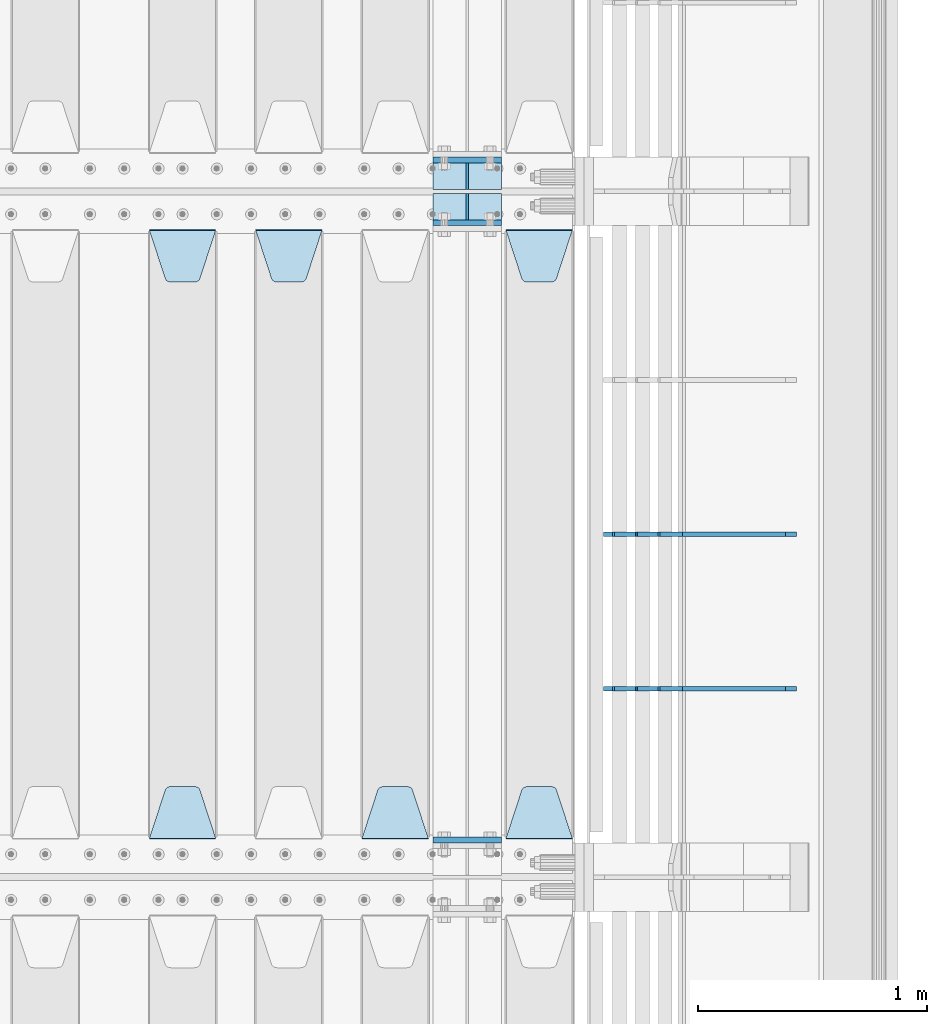
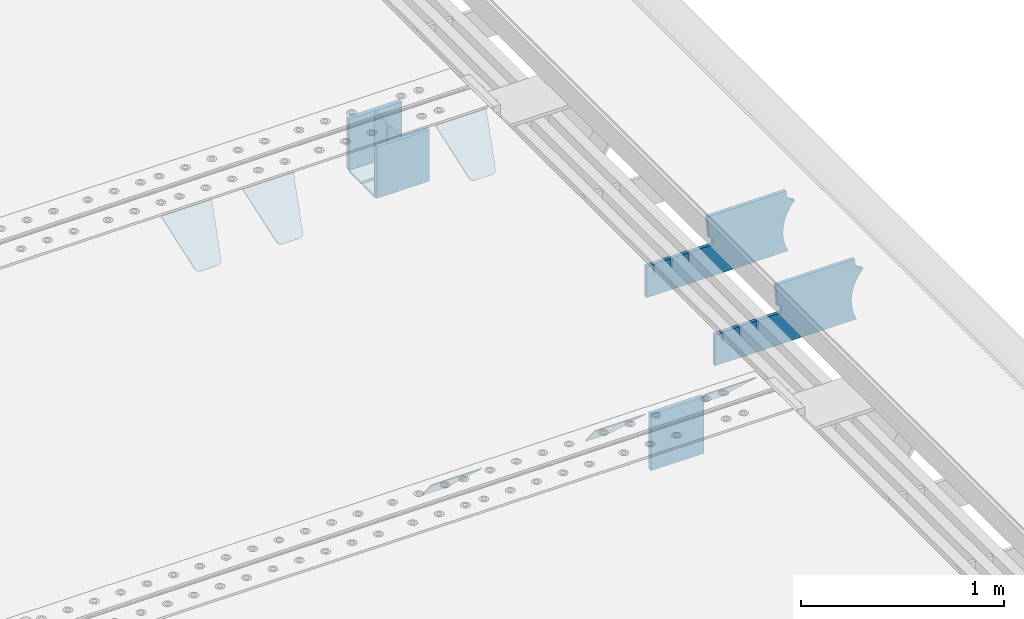
# One storey, part 237 of 257: 15 plates.
"""IFC2X3 building model written with IfcOpenShell, lengths in millimetres."""

from ifc_helpers import new_model, si_unit, frame, origin_with_axes, place, context, subcontext, project, spatial, faceted_brep, material, type_object, element, save


model = new_model("IFC2X3")

# Units and contexts
model_context = context("Model", 3, precision=1e-05, world=origin_with_axes())
body_context = subcontext(model_context, "Body", "Model", "MODEL_VIEW")
ifc_project = project(units=[si_unit("LENGTHUNIT", "METRE", prefix="MILLI"), si_unit("AREAUNIT", "SQUARE_METRE"), si_unit("VOLUMEUNIT", "CUBIC_METRE"), si_unit("MASSUNIT", "GRAM", prefix="KILO"), si_unit("TIMEUNIT", "SECOND"), si_unit("PLANEANGLEUNIT", "RADIAN"), si_unit("SOLIDANGLEUNIT", "STERADIAN"), si_unit("THERMODYNAMICTEMPERATUREUNIT", "DEGREE_CELSIUS"), si_unit("LUMINOUSINTENSITYUNIT", "LUMEN")], contexts=[model_context])

# Site, building, storey
site_placement = place(None, origin_with_axes())
site = spatial("IfcSite", under=ifc_project, at=site_placement, CompositionType="ELEMENT")
building_placement = place(site_placement, origin_with_axes())
building = spatial("IfcBuilding", under=site, at=building_placement, Name="Standard", CompositionType="ELEMENT")
storey_placement = place(building_placement, origin_with_axes())
storey = spatial("IfcBuildingStorey", under=building, at=storey_placement, Name="Undefined", CompositionType="ELEMENT", Elevation=0.0)

# Plates
ifc_material = material(Name="STEEL/S355N")
plate_type_1 = type_object("IfcPlateType", PredefinedType="NOTDEFINED")
for number, where, z_axis, x_axis in (
    (1, (58645.0, 6137.49999999999, -339.999999999993), (0.0, 0.0, 1.0), (1.0, 0.0, 0.0)),
    (2, (58645.0, 5862.49999999999, -339.999999999993), (0.0, 0.0, 1.0), (1.0, 0.0, 0.0)),
):
    element("IfcPlate", number, at=place(storey_placement, frame(where, z_axis=z_axis, x_axis=x_axis)), inside=storey, type_object=plate_type_1, material=ifc_material, context=body_context, shape_type="Brep", body=[
        faceted_brep([(0.0, -12.5, 0.0), (0.0, -12.5, 310.0), (0.0, 12.5, 310.0), (0.0, 12.5, 0.0), (300.0, -12.5, 310.0), (300.0, 12.5, 310.0), (300.0, -12.5, 0.0), (300.0, 12.5, 0.0)], [[[0, 1, 2, 3]], [[1, 4, 5, 2]], [[4, 6, 7, 5]], [[6, 0, 3, 7]], [[5, 7, 3, 2]], [[6, 4, 1, 0]]]),
    ])
plate_1_placement = place(storey_placement, frame((58645.0, 3162.5, -340.000000000044), z_axis=(0.0, 0.0, 1.0), x_axis=(1.0, 0.0, 0.0)))
element("IfcPlate", 3, at=plate_1_placement, inside=storey, type_object=plate_type_1, material=ifc_material, context=body_context, shape_type="Brep", body=[
    faceted_brep([(0.0, -12.5, 0.0), (0.0, -12.5, 340.0), (0.0, 12.5, 340.0), (0.0, 12.5, 0.0), (300.0, -12.5, 340.0), (300.0, 12.5, 340.0), (300.0, -12.5, 0.0), (300.0, 12.5, 0.0)], [[[0, 1, 2, 3]], [[1, 4, 5, 2]], [[4, 6, 7, 5]], [[6, 0, 3, 7]], [[5, 7, 3, 2]], [[6, 4, 1, 0]]]),
])
plate_type_2 = type_object("IfcPlateType", PredefinedType="NOTDEFINED")
for number, where, z_axis, x_axis in (
    (4, (58645.0, 5991.99999999999, -342.999999999993), (0.0, -1.0, 0.0), (1.0, 0.0, 0.0)),
    (5, (58645.0, 6007.99999999999, -342.999999999993), (0.0, 1.0, 0.0), (1.0, 0.0, 0.0)),
):
    element("IfcPlate", number, at=place(storey_placement, frame(where, z_axis=z_axis, x_axis=x_axis)), inside=storey, type_object=plate_type_2, material=ifc_material, context=body_context, shape_type="Brep", body=[
        faceted_brep([(0.0, -7.0, 0.0), (0.0, -7.0, 117.0), (0.0, 7.0, 117.0), (0.0, 7.0, 0.0), (300.0, -7.0, 117.0), (300.0, 7.0, 117.0), (300.0, -7.0, 0.0), (300.0, 7.0, 0.0)], [[[0, 1, 2, 3]], [[1, 4, 5, 2]], [[4, 6, 7, 5]], [[6, 0, 3, 7]], [[5, 7, 3, 2]], [[6, 4, 1, 0]]]),
    ])
plate_type_3 = type_object("IfcPlateType", PredefinedType="NOTDEFINED")
for number, where, z_axis, x_axis in (
    (6, (58795.0, 6007.99999999999, -29.999999999993), (0.0, 0.0, -1.0), (0.0, 1.0, 0.0)),
    (7, (58795.0, 5991.99999999999, -29.999999999993), (0.0, 0.0, -1.0), (0.0, -1.0, 0.0)),
):
    element("IfcPlate", number, at=place(storey_placement, frame(where, z_axis=z_axis, x_axis=x_axis)), inside=storey, type_object=plate_type_3, material=ifc_material, context=body_context, shape_type="Brep", body=[
        faceted_brep([(0.0, -5.0, 30.0), (0.0, -5.0, 306.0), (0.0, 5.0, 306.0), (0.0, 5.0, 30.0), (117.0, -5.0, 306.0), (117.0, 5.0, 306.0), (117.0, -5.0, 0.0), (117.0, 5.0, 0.0), (30.0, -5.0, 0.0), (30.0, 5.0, 0.0), (24.7905546699922, -5.0, 0.455767409633758), (24.7905546699922, 5.0, 0.455767409633758), (19.7393957002296, -5.0, 1.80922137642275), (19.7393957002296, 5.0, 1.80922137642275), (15.0, -5.0, 4.01923788646684), (15.0, 5.0, 4.01923788646684), (10.7163717094036, -5.0, 7.01866670643066), (10.7163717094036, 5.0, 7.01866670643066), (7.01866670643085, -5.0, 10.7163717094038), (7.01866670643085, 5.0, 10.7163717094038), (4.01923788646673, -5.0, 15.0), (4.01923788646673, 5.0, 15.0), (1.80922137642301, -5.0, 19.7393957002299), (1.80922137642301, 5.0, 19.7393957002299), (0.455767409634063, -5.0, 24.7905546699921), (0.455767409634063, 5.0, 24.7905546699921)], [[[0, 1, 2, 3]], [[1, 4, 5, 2]], [[4, 6, 7, 5]], [[6, 8, 9, 7]], [[8, 10, 11, 9]], [[10, 12, 13, 11]], [[12, 14, 15, 13]], [[14, 16, 17, 15]], [[16, 18, 19, 17]], [[18, 20, 21, 19]], [[20, 22, 23, 21]], [[22, 24, 25, 23]], [[24, 0, 3, 25]], [[5, 7, 9, 11, 13, 15, 17, 19, 21, 23, 25, 3, 2]], [[24, 22, 20, 18, 16, 14, 12, 10, 8, 6, 4, 1, 0]]]),
    ])
plate_type_4 = type_object("IfcPlateType", PredefinedType="NOTDEFINED")
plate_2_placement = place(storey_placement, frame((58965.0, 5831.76776695594, -1.767766952965), z_axis=(0.0, -0.707106781186548, -0.707106781186547), x_axis=(1.0, 0.0, 0.0)))
element("IfcPlate", 8, at=plate_2_placement, inside=storey, type_object=plate_type_4, material=ifc_material, context=body_context, shape_type="Brep", body=[
    faceted_brep([(0.0, -2.5, 0.0), (69.345504679477, -2.50000000000091, 300.17173142483), (69.345504679477, 2.5, 300.171731424831), (0.0, 2.5, 0.0), (70.927406119954, -2.50000000000091, 304.8974424154), (70.927406119954, 2.5, 304.8974424154), (73.3818627772271, -2.50000000000091, 309.234538108527), (73.3818627772271, 2.49999999999909, 309.234538108527), (76.6187032999587, -2.5, 313.023683126103), (76.6187032999587, 2.5, 313.023683126103), (80.5190132705029, -2.5, 316.125672595372), (80.5190132705029, 2.5, 316.125672595371), (84.9395038596849, -2.5, 318.426546230476), (84.9395038596849, 2.5, 318.426546230477), (89.7177759439219, -2.5, 319.841774983275), (89.7177759439219, 2.5, 319.841774983275), (94.6782862926484, -2.5, 320.319366455079), (94.6782862926484, 2.5, 320.319366455079), (195.321713707352, -2.5, 320.319366455079), (195.321713707352, 2.5, 320.319366455079), (200.282224056078, -2.5, 319.841774983275), (200.282224056078, 2.49999999999909, 319.841774983275), (205.060496140315, -2.5, 318.426546230476), (205.060496140315, 2.49999999999909, 318.426546230475), (209.480986729497, -2.5, 316.125672595371), (209.480986729497, 2.5, 316.125672595371), (213.381296700041, -2.50000000000091, 313.023683126102), (213.381296700041, 2.5, 313.023683126103), (216.618137222766, -2.50000000000091, 309.234538108527), (216.618137222766, 2.5, 309.234538108527), (219.072593880039, -2.5, 304.897442415399), (219.072593880039, 2.5, 304.897442415399), (220.654495320523, -2.50000000000091, 300.17173142483), (220.654495320523, 2.5, 300.171731424831), (290.0, -2.50000000000091, 0.0), (290.0, 2.5, 9.09494701772928e-13)], [[[0, 1, 2, 3]], [[1, 4, 5, 2]], [[4, 6, 7, 5]], [[6, 8, 9, 7]], [[8, 10, 11, 9]], [[10, 12, 13, 11]], [[12, 14, 15, 13]], [[14, 16, 17, 15]], [[16, 18, 19, 17]], [[18, 20, 21, 19]], [[20, 22, 23, 21]], [[22, 24, 25, 23]], [[24, 26, 27, 25]], [[26, 28, 29, 27]], [[28, 30, 31, 29]], [[30, 32, 33, 31]], [[32, 34, 35, 33]], [[34, 0, 3, 35]], [[5, 7, 9, 11, 13, 15, 17, 19, 21, 23, 25, 27, 29, 31, 33, 35, 3, 2]], [[34, 32, 30, 28, 26, 24, 22, 20, 18, 16, 14, 12, 10, 8, 6, 4, 1, 0]]]),
])
plate_3_placement = place(storey_placement, frame((59255.0, 3168.23223304703, -1.76776695296758), z_axis=(0.0, 0.707106781186547, -0.707106781186548), x_axis=(-1.0, 0.0, 0.0)))
element("IfcPlate", 9, at=plate_3_placement, inside=storey, type_object=plate_type_4, material=ifc_material, context=body_context, shape_type="Brep", body=[
    faceted_brep([(0.0, -2.5, 0.0), (69.345504679477, -2.50000000000091, 300.17173142483), (69.345504679477, 2.5, 300.171731424831), (0.0, 2.5, 0.0), (70.927406119954, -2.50000000000091, 304.8974424154), (70.927406119954, 2.5, 304.8974424154), (73.3818627772271, -2.50000000000091, 309.234538108527), (73.3818627772271, 2.49999999999909, 309.234538108527), (76.6187032999587, -2.5, 313.023683126103), (76.6187032999587, 2.5, 313.023683126103), (80.5190132705029, -2.5, 316.125672595372), (80.5190132705029, 2.5, 316.125672595371), (84.9395038596849, -2.5, 318.426546230476), (84.9395038596849, 2.5, 318.426546230477), (89.7177759439219, -2.5, 319.841774983275), (89.7177759439219, 2.5, 319.841774983275), (94.6782862926484, -2.5, 320.319366455079), (94.6782862926484, 2.5, 320.319366455079), (195.321713707352, -2.5, 320.319366455079), (195.321713707352, 2.5, 320.319366455079), (200.282224056078, -2.5, 319.841774983275), (200.282224056078, 2.49999999999909, 319.841774983275), (205.060496140315, -2.5, 318.426546230476), (205.060496140315, 2.49999999999909, 318.426546230475), (209.480986729497, -2.5, 316.125672595371), (209.480986729497, 2.5, 316.125672595371), (213.381296700041, -2.50000000000091, 313.023683126102), (213.381296700041, 2.5, 313.023683126103), (216.618137222766, -2.50000000000091, 309.234538108527), (216.618137222766, 2.5, 309.234538108527), (219.072593880039, -2.5, 304.897442415399), (219.072593880039, 2.5, 304.897442415399), (220.654495320523, -2.50000000000091, 300.17173142483), (220.654495320523, 2.5, 300.171731424831), (290.0, -2.50000000000091, 0.0), (290.0, 2.5, 9.09494701772928e-13)], [[[0, 1, 2, 3]], [[1, 4, 5, 2]], [[4, 6, 7, 5]], [[6, 8, 9, 7]], [[8, 10, 11, 9]], [[10, 12, 13, 11]], [[12, 14, 15, 13]], [[14, 16, 17, 15]], [[16, 18, 19, 17]], [[18, 20, 21, 19]], [[20, 22, 23, 21]], [[22, 24, 25, 23]], [[24, 26, 27, 25]], [[26, 28, 29, 27]], [[28, 30, 31, 29]], [[30, 32, 33, 31]], [[32, 34, 35, 33]], [[34, 0, 3, 35]], [[5, 7, 9, 11, 13, 15, 17, 19, 21, 23, 25, 27, 29, 31, 33, 35, 3, 2]], [[34, 32, 30, 28, 26, 24, 22, 20, 18, 16, 14, 12, 10, 8, 6, 4, 1, 0]]]),
])
plate_4_placement = place(storey_placement, frame((58625.0, 3168.23223304703, -1.76776695296758), z_axis=(0.0, 0.707106781186547, -0.707106781186548), x_axis=(-1.0, 0.0, 0.0)))
element("IfcPlate", 10, at=plate_4_placement, inside=storey, type_object=plate_type_4, material=ifc_material, context=body_context, shape_type="Brep", body=[
    faceted_brep([(0.0, -2.5, 0.0), (69.345504679477, -2.50000000000091, 300.17173142483), (69.345504679477, 2.5, 300.171731424831), (0.0, 2.5, 0.0), (70.927406119954, -2.50000000000091, 304.8974424154), (70.927406119954, 2.5, 304.8974424154), (73.3818627772271, -2.50000000000091, 309.234538108527), (73.3818627772271, 2.49999999999909, 309.234538108527), (76.6187032999587, -2.5, 313.023683126103), (76.6187032999587, 2.5, 313.023683126103), (80.5190132705029, -2.5, 316.125672595372), (80.5190132705029, 2.5, 316.125672595371), (84.9395038596849, -2.5, 318.426546230476), (84.9395038596849, 2.5, 318.426546230477), (89.7177759439219, -2.5, 319.841774983275), (89.7177759439219, 2.5, 319.841774983275), (94.6782862926484, -2.5, 320.319366455079), (94.6782862926484, 2.5, 320.319366455079), (195.321713707352, -2.5, 320.319366455079), (195.321713707352, 2.5, 320.319366455079), (200.282224056078, -2.5, 319.841774983275), (200.282224056078, 2.49999999999909, 319.841774983275), (205.060496140315, -2.5, 318.426546230476), (205.060496140315, 2.49999999999909, 318.426546230475), (209.480986729497, -2.5, 316.125672595371), (209.480986729497, 2.5, 316.125672595371), (213.381296700041, -2.50000000000091, 313.023683126102), (213.381296700041, 2.5, 313.023683126103), (216.618137222766, -2.50000000000091, 309.234538108527), (216.618137222766, 2.5, 309.234538108527), (219.072593880039, -2.5, 304.897442415399), (219.072593880039, 2.5, 304.897442415399), (220.654495320523, -2.50000000000091, 300.17173142483), (220.654495320523, 2.5, 300.171731424831), (290.0, -2.50000000000091, 0.0), (290.0, 2.5, 9.09494701772928e-13)], [[[0, 1, 2, 3]], [[1, 4, 5, 2]], [[4, 6, 7, 5]], [[6, 8, 9, 7]], [[8, 10, 11, 9]], [[10, 12, 13, 11]], [[12, 14, 15, 13]], [[14, 16, 17, 15]], [[16, 18, 19, 17]], [[18, 20, 21, 19]], [[20, 22, 23, 21]], [[22, 24, 25, 23]], [[24, 26, 27, 25]], [[26, 28, 29, 27]], [[28, 30, 31, 29]], [[30, 32, 33, 31]], [[32, 34, 35, 33]], [[34, 0, 3, 35]], [[5, 7, 9, 11, 13, 15, 17, 19, 21, 23, 25, 27, 29, 31, 33, 35, 3, 2]], [[34, 32, 30, 28, 26, 24, 22, 20, 18, 16, 14, 12, 10, 8, 6, 4, 1, 0]]]),
])
plate_5_placement = place(storey_placement, frame((57870.0, 5831.76776695594, -1.767766952965), z_axis=(0.0, -0.707106781186548, -0.707106781186547), x_axis=(1.0, 0.0, 0.0)))
element("IfcPlate", 11, at=plate_5_placement, inside=storey, type_object=plate_type_4, material=ifc_material, context=body_context, shape_type="Brep", body=[
    faceted_brep([(0.0, -2.5, 0.0), (69.345504679477, -2.50000000000091, 300.17173142483), (69.345504679477, 2.5, 300.171731424831), (0.0, 2.5, 0.0), (70.927406119954, -2.50000000000091, 304.8974424154), (70.927406119954, 2.5, 304.8974424154), (73.3818627772271, -2.50000000000091, 309.234538108527), (73.3818627772271, 2.49999999999909, 309.234538108527), (76.6187032999587, -2.5, 313.023683126103), (76.6187032999587, 2.5, 313.023683126103), (80.5190132705029, -2.5, 316.125672595372), (80.5190132705029, 2.5, 316.125672595371), (84.9395038596849, -2.5, 318.426546230476), (84.9395038596849, 2.5, 318.426546230477), (89.7177759439219, -2.5, 319.841774983275), (89.7177759439219, 2.5, 319.841774983275), (94.6782862926484, -2.5, 320.319366455079), (94.6782862926484, 2.5, 320.319366455079), (195.321713707352, -2.5, 320.319366455079), (195.321713707352, 2.5, 320.319366455079), (200.282224056078, -2.5, 319.841774983275), (200.282224056078, 2.49999999999909, 319.841774983275), (205.060496140315, -2.5, 318.426546230476), (205.060496140315, 2.49999999999909, 318.426546230475), (209.480986729497, -2.5, 316.125672595371), (209.480986729497, 2.5, 316.125672595371), (213.381296700041, -2.50000000000091, 313.023683126102), (213.381296700041, 2.5, 313.023683126103), (216.618137222766, -2.50000000000091, 309.234538108527), (216.618137222766, 2.5, 309.234538108527), (219.072593880039, -2.5, 304.897442415399), (219.072593880039, 2.5, 304.897442415399), (220.654495320523, -2.50000000000091, 300.17173142483), (220.654495320523, 2.5, 300.171731424831), (290.0, -2.50000000000091, 0.0), (290.0, 2.5, 9.09494701772928e-13)], [[[0, 1, 2, 3]], [[1, 4, 5, 2]], [[4, 6, 7, 5]], [[6, 8, 9, 7]], [[8, 10, 11, 9]], [[10, 12, 13, 11]], [[12, 14, 15, 13]], [[14, 16, 17, 15]], [[16, 18, 19, 17]], [[18, 20, 21, 19]], [[20, 22, 23, 21]], [[22, 24, 25, 23]], [[24, 26, 27, 25]], [[26, 28, 29, 27]], [[28, 30, 31, 29]], [[30, 32, 33, 31]], [[32, 34, 35, 33]], [[34, 0, 3, 35]], [[5, 7, 9, 11, 13, 15, 17, 19, 21, 23, 25, 27, 29, 31, 33, 35, 3, 2]], [[34, 32, 30, 28, 26, 24, 22, 20, 18, 16, 14, 12, 10, 8, 6, 4, 1, 0]]]),
])
plate_6_placement = place(storey_placement, frame((57405.0, 5831.76776695594, -1.767766952965), z_axis=(0.0, -0.707106781186548, -0.707106781186547), x_axis=(1.0, 0.0, 0.0)))
element("IfcPlate", 12, at=plate_6_placement, inside=storey, type_object=plate_type_4, material=ifc_material, context=body_context, shape_type="Brep", body=[
    faceted_brep([(0.0, -2.5, 0.0), (69.345504679477, -2.50000000000091, 300.17173142483), (69.345504679477, 2.5, 300.171731424831), (0.0, 2.5, 0.0), (70.927406119954, -2.50000000000091, 304.8974424154), (70.927406119954, 2.5, 304.8974424154), (73.3818627772271, -2.50000000000091, 309.234538108527), (73.3818627772271, 2.49999999999909, 309.234538108527), (76.6187032999587, -2.5, 313.023683126103), (76.6187032999587, 2.5, 313.023683126103), (80.5190132705029, -2.5, 316.125672595372), (80.5190132705029, 2.5, 316.125672595371), (84.9395038596849, -2.5, 318.426546230476), (84.9395038596849, 2.5, 318.426546230477), (89.7177759439219, -2.5, 319.841774983275), (89.7177759439219, 2.5, 319.841774983275), (94.6782862926484, -2.5, 320.319366455079), (94.6782862926484, 2.5, 320.319366455079), (195.321713707352, -2.5, 320.319366455079), (195.321713707352, 2.5, 320.319366455079), (200.282224056078, -2.5, 319.841774983275), (200.282224056078, 2.49999999999909, 319.841774983275), (205.060496140315, -2.5, 318.426546230476), (205.060496140315, 2.49999999999909, 318.426546230475), (209.480986729497, -2.5, 316.125672595371), (209.480986729497, 2.5, 316.125672595371), (213.381296700041, -2.50000000000091, 313.023683126102), (213.381296700041, 2.5, 313.023683126103), (216.618137222766, -2.50000000000091, 309.234538108527), (216.618137222766, 2.5, 309.234538108527), (219.072593880039, -2.5, 304.897442415399), (219.072593880039, 2.5, 304.897442415399), (220.654495320523, -2.50000000000091, 300.17173142483), (220.654495320523, 2.5, 300.171731424831), (290.0, -2.50000000000091, 0.0), (290.0, 2.5, 9.09494701772928e-13)], [[[0, 1, 2, 3]], [[1, 4, 5, 2]], [[4, 6, 7, 5]], [[6, 8, 9, 7]], [[8, 10, 11, 9]], [[10, 12, 13, 11]], [[12, 14, 15, 13]], [[14, 16, 17, 15]], [[16, 18, 19, 17]], [[18, 20, 21, 19]], [[20, 22, 23, 21]], [[22, 24, 25, 23]], [[24, 26, 27, 25]], [[26, 28, 29, 27]], [[28, 30, 31, 29]], [[30, 32, 33, 31]], [[32, 34, 35, 33]], [[34, 0, 3, 35]], [[5, 7, 9, 11, 13, 15, 17, 19, 21, 23, 25, 27, 29, 31, 33, 35, 3, 2]], [[34, 32, 30, 28, 26, 24, 22, 20, 18, 16, 14, 12, 10, 8, 6, 4, 1, 0]]]),
])
plate_7_placement = place(storey_placement, frame((57695.0, 3168.23223304703, -1.76776695296758), z_axis=(0.0, 0.707106781186547, -0.707106781186548), x_axis=(-1.0, 0.0, 0.0)))
element("IfcPlate", 13, at=plate_7_placement, inside=storey, type_object=plate_type_4, material=ifc_material, context=body_context, shape_type="Brep", body=[
    faceted_brep([(0.0, -2.5, 0.0), (69.345504679477, -2.50000000000091, 300.17173142483), (69.345504679477, 2.5, 300.171731424831), (0.0, 2.5, 0.0), (70.927406119954, -2.50000000000091, 304.8974424154), (70.927406119954, 2.5, 304.8974424154), (73.3818627772271, -2.50000000000091, 309.234538108527), (73.3818627772271, 2.49999999999909, 309.234538108527), (76.6187032999587, -2.5, 313.023683126103), (76.6187032999587, 2.5, 313.023683126103), (80.5190132705029, -2.5, 316.125672595372), (80.5190132705029, 2.5, 316.125672595371), (84.9395038596849, -2.5, 318.426546230476), (84.9395038596849, 2.5, 318.426546230477), (89.7177759439219, -2.5, 319.841774983275), (89.7177759439219, 2.5, 319.841774983275), (94.6782862926484, -2.5, 320.319366455079), (94.6782862926484, 2.5, 320.319366455079), (195.321713707352, -2.5, 320.319366455079), (195.321713707352, 2.5, 320.319366455079), (200.282224056078, -2.5, 319.841774983275), (200.282224056078, 2.49999999999909, 319.841774983275), (205.060496140315, -2.5, 318.426546230476), (205.060496140315, 2.49999999999909, 318.426546230475), (209.480986729497, -2.5, 316.125672595371), (209.480986729497, 2.5, 316.125672595371), (213.381296700041, -2.50000000000091, 313.023683126102), (213.381296700041, 2.5, 313.023683126103), (216.618137222766, -2.50000000000091, 309.234538108527), (216.618137222766, 2.5, 309.234538108527), (219.072593880039, -2.5, 304.897442415399), (219.072593880039, 2.5, 304.897442415399), (220.654495320523, -2.50000000000091, 300.17173142483), (220.654495320523, 2.5, 300.171731424831), (290.0, -2.50000000000091, 0.0), (290.0, 2.5, 9.09494701772928e-13)], [[[0, 1, 2, 3]], [[1, 4, 5, 2]], [[4, 6, 7, 5]], [[6, 8, 9, 7]], [[8, 10, 11, 9]], [[10, 12, 13, 11]], [[12, 14, 15, 13]], [[14, 16, 17, 15]], [[16, 18, 19, 17]], [[18, 20, 21, 19]], [[20, 22, 23, 21]], [[22, 24, 25, 23]], [[24, 26, 27, 25]], [[26, 28, 29, 27]], [[28, 30, 31, 29]], [[30, 32, 33, 31]], [[32, 34, 35, 33]], [[34, 0, 3, 35]], [[5, 7, 9, 11, 13, 15, 17, 19, 21, 23, 25, 27, 29, 31, 33, 35, 3, 2]], [[34, 32, 30, 28, 26, 24, 22, 20, 18, 16, 14, 12, 10, 8, 6, 4, 1, 0]]]),
])
plate_type_5 = type_object("IfcPlateType", PredefinedType="NOTDEFINED")
plate_8_placement = place(storey_placement, frame((60232.9182339676, 3824.99928283691, -374.002067436517), z_axis=(0.0, 0.0, 1.0), x_axis=(-1.0, 0.0, 0.0)))
element("IfcPlate", 14, at=plate_8_placement, inside=storey, type_object=plate_type_5, material=ifc_material, context=body_context, shape_type="Brep", body=[
    faceted_brep([(801.919404066546, -10.0, 188.0), (801.919404066546, 10.0, 188.0), (801.919404066546, 10.0, 132.002067436952), (801.919404066546, -10.0, 132.002067436952), (793.919404066546, 10.0, 132.002067436952), (793.919404066546, -10.0, 132.002067436952), (793.919404066546, 10.0, 180.002067436952), (793.919404066546, -10.0, 180.002067436952), (793.52785619691, 10.0, 182.474203391951), (793.52785619691, -10.0, 182.474203391951), (792.391540021548, 10.0, 184.704349455291), (792.391540021548, -10.0, 184.704349455291), (790.621686084887, 10.0, 186.474203391951), (790.621686084887, -10.0, 186.474203391951), (788.391540021548, 10.0, 187.610519567313), (788.391540021548, -10.0, 187.610519567313), (785.919404066546, -10.0, 188.002067436952), (785.919404066546, 10.0, 188.0), (841.0, -10.0, 188.0), (841.0, -10.0, 0.0), (841.0, 10.0, 0.0), (841.0, 10.0, 188.0), (33.3619566735943, -10.0, 0.0), (33.3619566735943, 10.0, 0.0), (36.2350612208102, -10.0, 4.68848050267013), (36.2350612208102, 10.0, 4.68848050267013), (51.4877592159319, -10.0, 41.5117508652784), (51.4877592159319, 10.0, 41.5117508652784), (60.7922425881334, -10.0, 80.2677133162964), (60.7922425881334, 10.0, 80.2677133162964), (63.9194040769653, -10.0, 120.002067436515), (63.9194040769653, 10.0, 120.002067436515), (60.7922425881334, -10.0, 159.736421556734), (60.7922425881334, 10.0, 159.736421556734), (51.4877592159319, -10.0, 198.492384007752), (51.4877592159319, 10.0, 198.492384007752), (36.2350612208102, -10.0, 235.31565437036), (36.2350612208102, 10.0, 235.31565437036), (15.4097206482038, -10.0, 269.299521518803), (15.4097206482038, 10.0, 269.299521518803), (-3.35474438100209, -10.0, 291.269887256574), (-3.35474438100209, 10.0, 291.269887256574), (-2.36881039375294, -10.0000000000001, 291.426043859339), (-2.36881039375294, 10.0, 291.426043859339), (17.1449676604752, -10.0000000000001, 301.368810393754), (17.1449676604752, 10.0, 301.368810393754), (32.6311896062471, -10.0000000000001, 316.855032339527), (32.6311896062471, 10.0, 316.855032339527), (42.573956140659, -10.0000000000001, 336.368810393754), (42.573956140659, 10.0, 336.368810393754), (46.0, -10.0000000000001, 358.0), (46.0, 10.0, 358.0), (45.0495205499174, -10.0, 364.001091067617), (45.0495205499174, 10.0, 364.001091067617), (495.040008544922, -10.0, 364.010009765625), (495.040008544922, 10.0, 364.010009765625), (483.600036621094, -10.0, 233.759994506836), (483.600036621094, 10.0, 233.759994506836), (472.0, -10.0, 233.759994506836), (472.0, 10.0, 233.759994506836), (468.909830056247, -10.0, 233.270559669787), (468.909830056247, 10.0, 233.270559669787), (466.122147477072, -10.0, 231.850164450585), (466.122147477072, 10.0, 231.850164450585), (463.909830056247, -10.0, 229.637847029761), (463.909830056247, 10.0, 229.637847029761), (462.489434837051, -10.0, 226.850164450585), (462.489434837051, 10.0, 226.850164450585), (462.0, -10.0, 223.759994506836), (462.0, 10.0, 223.759994506836), (462.0, -10.0, 198.0), (462.0, 10.0, 198.0), (462.489434837051, -10.0, 194.909830056251), (462.489434837051, 10.0, 194.909830056251), (463.909830056247, -10.0, 192.122147477075), (463.909830056247, 10.0, 192.122147477075), (466.122147477072, -10.0, 189.909830056251), (466.122147477072, 10.0, 189.909830056251), (468.909830056247, -10.0, 188.489434837048), (468.909830056247, 10.0, 188.489434837048), (472.0, -10.0, 188.0), (472.0, 10.0, 188.0), (585.919404066546, -10.0, 188.002067436952), (585.919404066546, 10.0, 188.0), (588.391540021548, -10.0, 187.610519567313), (588.391540021548, 10.0, 187.610519567313), (590.621686084887, -10.0, 186.474203391951), (590.621686084887, 10.0, 186.474203391951), (592.391540021548, -10.0, 184.704349455291), (592.391540021548, 10.0, 184.704349455291), (593.52785619691, -10.0, 182.474203391951), (593.52785619691, 10.0, 182.474203391951), (593.919404066546, -10.0, 180.002067436952), (593.919404066546, 10.0, 180.002067436952), (593.919404066546, -10.0, 132.002067436952), (593.919404066546, 10.0, 132.002067436952), (601.919404066546, -10.0, 132.002067436952), (601.919404066546, 10.0, 132.002067436952), (601.919404066546, -10.0, 188.0), (601.919404066546, 10.0, 188.0), (685.919404066546, -10.0, 188.002067436952), (685.919404066546, 10.0, 188.0), (688.391540021548, -9.99999999999977, 187.610519567313), (688.391540021548, 10.0, 187.610519567313), (690.621686084887, -9.99999999999977, 186.474203391951), (690.621686084887, 10.0, 186.474203391951), (692.391540021548, -9.99999999999977, 184.704349455291), (692.391540021548, 10.0, 184.704349455291), (693.52785619691, -9.99999999999977, 182.474203391951), (693.52785619691, 10.0, 182.474203391951), (693.919404066546, -9.99999999999977, 180.002067436952), (693.919404066546, 10.0, 180.002067436952), (693.919404066546, -9.99999999999977, 132.002067436952), (693.919404066546, 10.0, 132.002067436952), (701.919404066546, -9.99999999999977, 132.002067436952), (701.919404066546, 10.0, 132.002067436952), (701.919404066546, -10.0, 188.0), (701.919404066546, 10.0, 188.0)], [[[0, 1, 2, 3]], [[3, 2, 4, 5]], [[5, 4, 6, 7]], [[7, 6, 8, 9]], [[9, 8, 10, 11]], [[11, 10, 12, 13]], [[13, 12, 14, 15]], [[16, 15, 14, 17]], [[18, 19, 20, 21]], [[20, 19, 22, 23]], [[22, 24, 25, 23]], [[26, 27, 25, 24]], [[28, 29, 27, 26]], [[30, 31, 29, 28]], [[32, 33, 31, 30]], [[34, 35, 33, 32]], [[36, 37, 35, 34]], [[38, 39, 37, 36]], [[39, 38, 40, 41]], [[40, 42, 43, 41]], [[44, 45, 43, 42]], [[46, 47, 45, 44]], [[48, 49, 47, 46]], [[50, 51, 49, 48]], [[52, 53, 51, 50]], [[54, 55, 53, 52]], [[54, 56, 57, 55]], [[56, 58, 59, 57]], [[58, 60, 61, 59]], [[60, 62, 63, 61]], [[62, 64, 65, 63]], [[64, 66, 67, 65]], [[66, 68, 69, 67]], [[68, 70, 71, 69]], [[70, 72, 73, 71]], [[72, 74, 75, 73]], [[74, 76, 77, 75]], [[76, 78, 79, 77]], [[78, 80, 81, 79]], [[81, 80, 82, 83]], [[82, 84, 85, 83]], [[86, 87, 85, 84]], [[88, 89, 87, 86]], [[90, 91, 89, 88]], [[92, 93, 91, 90]], [[94, 95, 93, 92]], [[96, 97, 95, 94]], [[98, 99, 97, 96]], [[99, 98, 100, 101]], [[100, 102, 103, 101]], [[104, 105, 103, 102]], [[106, 107, 105, 104]], [[108, 109, 107, 106]], [[110, 111, 109, 108]], [[112, 113, 111, 110]], [[114, 115, 113, 112]], [[116, 117, 115, 114]], [[117, 116, 16, 17]], [[12, 10, 8, 6, 4, 2, 1, 21, 20, 23, 25, 27, 29, 31, 33, 35, 37, 39, 41, 43, 45, 47, 49, 51, 53, 55, 57, 59, 61, 63, 65, 67, 69, 71, 73, 75, 77, 79, 81, 83, 85, 87, 89, 91, 93, 95, 97, 99, 101, 103, 105, 107, 109, 111, 113, 115, 117, 17, 14]], [[18, 21, 1, 0]], [[116, 114, 112, 110, 108, 106, 104, 102, 100, 98, 96, 94, 92, 90, 88, 86, 84, 82, 80, 78, 76, 74, 72, 70, 68, 66, 64, 62, 60, 58, 56, 54, 52, 50, 48, 46, 44, 42, 40, 38, 36, 34, 32, 30, 28, 26, 24, 22, 19, 18, 0, 3, 5, 7, 9, 11, 13, 15, 16]]]),
])
plate_9_placement = place(storey_placement, frame((60232.9182339676, 4499.99928283691, -374.002067436517), z_axis=(0.0, 0.0, 1.0), x_axis=(-1.0, 0.0, 0.0)))
element("IfcPlate", 15, at=plate_9_placement, inside=storey, type_object=plate_type_5, material=ifc_material, context=body_context, shape_type="Brep", body=[
    faceted_brep([(801.919404066546, -10.0, 188.0), (801.919404066546, 10.0, 188.0), (801.919404066546, 10.0, 132.002067436952), (801.919404066546, -10.0, 132.002067436952), (793.919404066546, 10.0, 132.002067436952), (793.919404066546, -10.0, 132.002067436952), (793.919404066546, 10.0, 180.002067436952), (793.919404066546, -10.0, 180.002067436952), (793.52785619691, 10.0, 182.474203391951), (793.52785619691, -10.0, 182.474203391951), (792.391540021548, 10.0, 184.704349455291), (792.391540021548, -10.0, 184.704349455291), (790.621686084887, 10.0, 186.474203391951), (790.621686084887, -10.0, 186.474203391951), (788.391540021548, 10.0, 187.610519567313), (788.391540021548, -10.0, 187.610519567313), (785.919404066546, -10.0, 188.002067436952), (785.919404066546, 10.0, 188.0), (841.0, -10.0, 188.0), (841.0, -10.0, 0.0), (841.0, 10.0, 0.0), (841.0, 10.0, 188.0), (33.3619566735943, -10.0, 0.0), (33.3619566735943, 10.0, 0.0), (36.2350612208102, -10.0, 4.68848050267013), (36.2350612208102, 10.0, 4.68848050267013), (51.4877592159319, -10.0, 41.5117508652784), (51.4877592159319, 10.0, 41.5117508652784), (60.7922425881334, -10.0, 80.2677133162964), (60.7922425881334, 10.0, 80.2677133162964), (63.9194040769653, -10.0, 120.002067436515), (63.9194040769653, 10.0, 120.002067436515), (60.7922425881334, -10.0, 159.736421556734), (60.7922425881334, 10.0, 159.736421556734), (51.4877592159319, -10.0, 198.492384007752), (51.4877592159319, 10.0, 198.492384007752), (36.2350612208102, -10.0, 235.31565437036), (36.2350612208102, 10.0, 235.31565437036), (15.4097206482038, -10.0, 269.299521518803), (15.4097206482038, 10.0, 269.299521518803), (-3.35474438100209, -10.0, 291.269887256574), (-3.35474438100209, 10.0, 291.269887256574), (-2.36881039375294, -10.0000000000001, 291.426043859339), (-2.36881039375294, 10.0, 291.426043859339), (17.1449676604752, -10.0000000000001, 301.368810393754), (17.1449676604752, 10.0, 301.368810393754), (32.6311896062471, -10.0000000000001, 316.855032339527), (32.6311896062471, 10.0, 316.855032339527), (42.573956140659, -10.0000000000001, 336.368810393754), (42.573956140659, 10.0, 336.368810393754), (46.0, -10.0000000000001, 358.0), (46.0, 10.0, 358.0), (45.0495205499174, -10.0, 364.001091067617), (45.0495205499174, 10.0, 364.001091067617), (495.040008544922, -10.0, 364.010009765625), (495.040008544922, 10.0, 364.010009765625), (483.600036621094, -10.0, 233.759994506836), (483.600036621094, 10.0, 233.759994506836), (472.0, -10.0, 233.759994506836), (472.0, 10.0, 233.759994506836), (468.909830056247, -10.0, 233.270559669787), (468.909830056247, 10.0, 233.270559669787), (466.122147477072, -10.0, 231.850164450585), (466.122147477072, 10.0, 231.850164450585), (463.909830056247, -10.0, 229.637847029761), (463.909830056247, 10.0, 229.637847029761), (462.489434837051, -10.0, 226.850164450585), (462.489434837051, 10.0, 226.850164450585), (462.0, -10.0, 223.759994506836), (462.0, 10.0, 223.759994506836), (462.0, -10.0, 198.0), (462.0, 10.0, 198.0), (462.489434837051, -10.0, 194.909830056251), (462.489434837051, 10.0, 194.909830056251), (463.909830056247, -10.0, 192.122147477075), (463.909830056247, 10.0, 192.122147477075), (466.122147477072, -10.0, 189.909830056251), (466.122147477072, 10.0, 189.909830056251), (468.909830056247, -10.0, 188.489434837048), (468.909830056247, 10.0, 188.489434837048), (472.0, -10.0, 188.0), (472.0, 10.0, 188.0), (585.919404066546, -10.0, 188.002067436952), (585.919404066546, 10.0, 188.0), (588.391540021548, -10.0, 187.610519567313), (588.391540021548, 10.0, 187.610519567313), (590.621686084887, -10.0, 186.474203391951), (590.621686084887, 10.0, 186.474203391951), (592.391540021548, -10.0, 184.704349455291), (592.391540021548, 10.0, 184.704349455291), (593.52785619691, -10.0, 182.474203391951), (593.52785619691, 10.0, 182.474203391951), (593.919404066546, -10.0, 180.002067436952), (593.919404066546, 10.0, 180.002067436952), (593.919404066546, -10.0, 132.002067436952), (593.919404066546, 10.0, 132.002067436952), (601.919404066546, -10.0, 132.002067436952), (601.919404066546, 10.0, 132.002067436952), (601.919404066546, -10.0, 188.0), (601.919404066546, 10.0, 188.0), (685.919404066546, -10.0, 188.002067436952), (685.919404066546, 10.0, 188.0), (688.391540021548, -9.99999999999977, 187.610519567313), (688.391540021548, 10.0, 187.610519567313), (690.621686084887, -9.99999999999977, 186.474203391951), (690.621686084887, 10.0, 186.474203391951), (692.391540021548, -9.99999999999977, 184.704349455291), (692.391540021548, 10.0, 184.704349455291), (693.52785619691, -9.99999999999977, 182.474203391951), (693.52785619691, 10.0, 182.474203391951), (693.919404066546, -9.99999999999977, 180.002067436952), (693.919404066546, 10.0, 180.002067436952), (693.919404066546, -9.99999999999977, 132.002067436952), (693.919404066546, 10.0, 132.002067436952), (701.919404066546, -9.99999999999977, 132.002067436952), (701.919404066546, 10.0, 132.002067436952), (701.919404066546, -10.0, 188.0), (701.919404066546, 10.0, 188.0)], [[[0, 1, 2, 3]], [[3, 2, 4, 5]], [[5, 4, 6, 7]], [[7, 6, 8, 9]], [[9, 8, 10, 11]], [[11, 10, 12, 13]], [[13, 12, 14, 15]], [[16, 15, 14, 17]], [[18, 19, 20, 21]], [[20, 19, 22, 23]], [[22, 24, 25, 23]], [[26, 27, 25, 24]], [[28, 29, 27, 26]], [[30, 31, 29, 28]], [[32, 33, 31, 30]], [[34, 35, 33, 32]], [[36, 37, 35, 34]], [[38, 39, 37, 36]], [[39, 38, 40, 41]], [[40, 42, 43, 41]], [[44, 45, 43, 42]], [[46, 47, 45, 44]], [[48, 49, 47, 46]], [[50, 51, 49, 48]], [[52, 53, 51, 50]], [[54, 55, 53, 52]], [[54, 56, 57, 55]], [[56, 58, 59, 57]], [[58, 60, 61, 59]], [[60, 62, 63, 61]], [[62, 64, 65, 63]], [[64, 66, 67, 65]], [[66, 68, 69, 67]], [[68, 70, 71, 69]], [[70, 72, 73, 71]], [[72, 74, 75, 73]], [[74, 76, 77, 75]], [[76, 78, 79, 77]], [[78, 80, 81, 79]], [[81, 80, 82, 83]], [[82, 84, 85, 83]], [[86, 87, 85, 84]], [[88, 89, 87, 86]], [[90, 91, 89, 88]], [[92, 93, 91, 90]], [[94, 95, 93, 92]], [[96, 97, 95, 94]], [[98, 99, 97, 96]], [[99, 98, 100, 101]], [[100, 102, 103, 101]], [[104, 105, 103, 102]], [[106, 107, 105, 104]], [[108, 109, 107, 106]], [[110, 111, 109, 108]], [[112, 113, 111, 110]], [[114, 115, 113, 112]], [[116, 117, 115, 114]], [[117, 116, 16, 17]], [[12, 10, 8, 6, 4, 2, 1, 21, 20, 23, 25, 27, 29, 31, 33, 35, 37, 39, 41, 43, 45, 47, 49, 51, 53, 55, 57, 59, 61, 63, 65, 67, 69, 71, 73, 75, 77, 79, 81, 83, 85, 87, 89, 91, 93, 95, 97, 99, 101, 103, 105, 107, 109, 111, 113, 115, 117, 17, 14]], [[18, 21, 1, 0]], [[116, 114, 112, 110, 108, 106, 104, 102, 100, 98, 96, 94, 92, 90, 88, 86, 84, 82, 80, 78, 76, 74, 72, 70, 68, 66, 64, 62, 60, 58, 56, 54, 52, 50, 48, 46, 44, 42, 40, 38, 36, 34, 32, 30, 28, 26, 24, 22, 19, 18, 0, 3, 5, 7, 9, 11, 13, 15, 16]]]),
])

save(model, "model.ifc")
